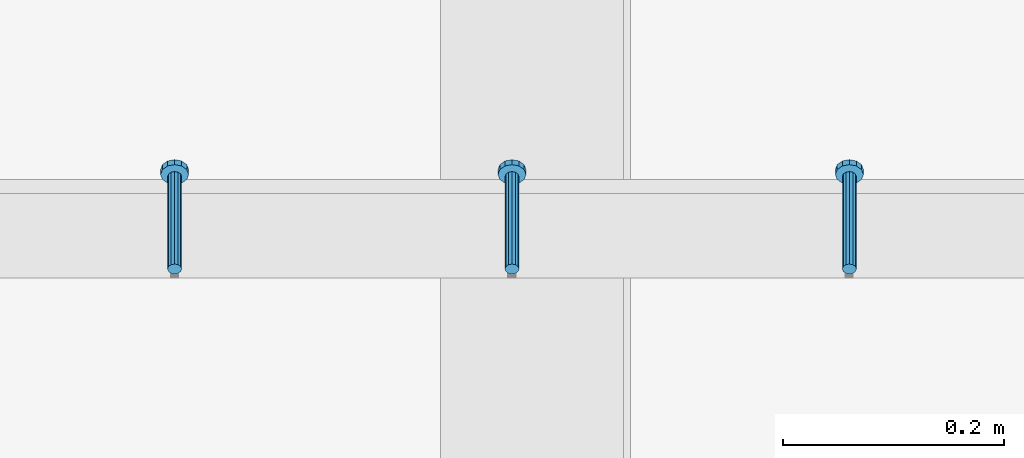
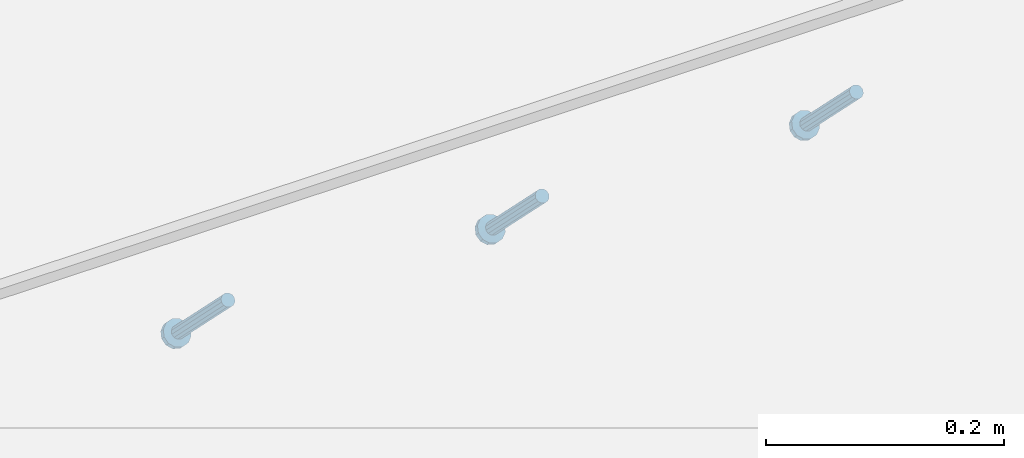
# One storey, part 2343 of 3843: 3 members, 1 element without a shape of its own.
"""IFC2X3 building model written with IfcOpenShell, lengths in millimetres."""

from ifc_helpers import new_model, si_unit, frame, origin_with_axes, place, context, subcontext, project, spatial, faceted_brep, material, type_object, element, aggregate, save


model = new_model("IFC2X3")

# Units and contexts
model_context = context("Model", 3, precision=1e-05, world=origin_with_axes())
body_context = subcontext(model_context, "Body", "Model", "MODEL_VIEW")
ifc_project = project(units=[si_unit("LENGTHUNIT", "METRE", prefix="MILLI"), si_unit("AREAUNIT", "SQUARE_METRE"), si_unit("VOLUMEUNIT", "CUBIC_METRE"), si_unit("MASSUNIT", "GRAM", prefix="KILO"), si_unit("TIMEUNIT", "SECOND"), si_unit("PLANEANGLEUNIT", "RADIAN"), si_unit("SOLIDANGLEUNIT", "STERADIAN"), si_unit("THERMODYNAMICTEMPERATUREUNIT", "DEGREE_CELSIUS"), si_unit("LUMINOUSINTENSITYUNIT", "LUMEN")], contexts=[model_context])

# Site, building, storey
site_placement = place(None, origin_with_axes())
site = spatial("IfcSite", under=ifc_project, at=site_placement, CompositionType="ELEMENT")
building_placement = place(site_placement, origin_with_axes())
building = spatial("IfcBuilding", under=site, at=building_placement, Name="Undefined", CompositionType="ELEMENT")
storey_placement = place(building_placement, origin_with_axes())
storey = spatial("IfcBuildingStorey", under=building, at=storey_placement, Name="Undefined", CompositionType="ELEMENT", Elevation=0.0)

# Assembly, members
assembly_placement = place(storey_placement, origin_with_axes())
assembly = element("IfcElementAssembly", 1, at=assembly_placement, inside=storey, Name="EMBED_ANGLE", AssemblyPlace="NOTDEFINED", PredefinedType="RIGID_FRAME")
ifc_material = material(Name="STEEL/A108")
member_type = type_object("IfcMemberType", PredefinedType="NOTDEFINED")
member_1_placement = place(assembly_placement, frame((61240.1619023437, 62012.5124999965, 30446.6625000001), z_axis=(-1.0, 0.0, 0.0), x_axis=(5.70000238222118e-08, 0.707106781186546, -0.707106781186546)))
member_1 = element("IfcMember", 2, at=member_1_placement, type_object=member_type, material=ifc_material, Name="HEADED STUD ANCHOR", context=body_context, shape_type="Brep", body=[
    faceted_brep([(7.27595761418343e-12, -3.18000006675175, 5.5), (0.0, -5.49999999998363, 3.1800000667572), (118.110000000976, -5.49999999999091, 3.1800000667572), (118.110000000983, -3.18000006675175, 5.5), (0.0, -6.3499999046162, 0.0), (118.110000000968, -6.34999990461256, 0.0), (0.0, -5.49999999998363, -3.1800000667572), (118.110000000976, -5.49999999999091, -3.1800000667572), (7.27595761418343e-12, -3.18000006675175, -5.5), (118.110000000983, -3.18000006675175, -5.5), (7.27595761418343e-12, -1.81898940354586e-12, -6.34999990463257), (118.110000000968, -1.81898940354586e-12, -6.34999990463257), (0.0, 3.18000006675175, -5.5), (118.110000000968, 3.18000006674811, -5.5), (7.27595761418343e-12, 5.49999999998363, -3.1800000667572), (118.110000000983, 5.49999999998363, -3.1800000667572), (7.27595761418343e-12, 6.3499999046162, 0.0), (118.110000000976, 6.34999990461256, 0.0), (7.27595761418343e-12, 5.49999999998363, 3.1800000667572), (118.110000000983, 5.49999999998363, 3.1800000667572), (0.0, 3.18000006675175, 5.5), (118.110000000968, 3.18000006674811, 5.5), (7.27595761418343e-12, -1.81898940354586e-12, 6.34999990463257), (118.110000000968, -1.81898940354586e-12, 6.34999990463257), (120.650000000991, -10.9899997710909, 6.34999990463257), (120.650000000998, -6.34000015257152, 10.9899997711182), (120.650000000991, -12.6999998092379, 0.0), (120.650000000991, -10.9899997710909, -6.34999990463257), (120.650000000998, -6.34000015257152, -10.9899997711182), (120.650000000991, -1.81898940354586e-12, -12.6899995803833), (120.650000000991, 6.34000015257152, -10.9899997711182), (120.650000000998, 10.9899997710909, -6.34999990463257), (120.650000000991, 12.6999998092342, 0.0), (120.650000000998, 10.9899997710909, 6.34999990463257), (120.650000000991, 6.34000015257152, 10.9899997711182), (120.650000000991, -1.81898940354586e-12, 12.6899995803833), (127.000000001048, -10.9899997710945, 6.34999990463257), (127.000000001048, -6.34000015257152, 10.9899997711182), (127.000000001048, -12.6999998092342, 0.0), (127.000000001048, -10.9899997710945, -6.34999990463257), (127.000000001048, -6.34000015257152, -10.9899997711182), (127.000000001048, 1.81898940354586e-12, -12.6899995803833), (127.000000001048, 6.34000015256788, -10.9899997711182), (127.000000001048, 10.9899997710909, -6.34999990463257), (127.000000001048, 12.6999998092379, 0.0), (127.000000001048, 10.9899997710909, 6.34999990463257), (127.000000001048, 6.34000015256788, 10.9899997711182), (127.000000001048, 1.81898940354586e-12, 12.6899995803833)], [[[0, 1, 2, 3]], [[1, 4, 5, 2]], [[4, 6, 7, 5]], [[6, 8, 9, 7]], [[8, 10, 11, 9]], [[10, 12, 13, 11]], [[12, 14, 15, 13]], [[14, 16, 17, 15]], [[16, 18, 19, 17]], [[18, 20, 21, 19]], [[20, 22, 23, 21]], [[22, 0, 3, 23]], [[22, 20, 18, 16, 14, 12, 10, 8, 6, 4, 1, 0]], [[3, 2, 24, 25]], [[2, 5, 26, 24]], [[5, 7, 27, 26]], [[7, 9, 28, 27]], [[9, 11, 29, 28]], [[11, 13, 30, 29]], [[13, 15, 31, 30]], [[15, 17, 32, 31]], [[17, 19, 33, 32]], [[19, 21, 34, 33]], [[21, 23, 35, 34]], [[23, 3, 25, 35]], [[25, 24, 36, 37]], [[24, 26, 38, 36]], [[26, 27, 39, 38]], [[27, 28, 40, 39]], [[28, 29, 41, 40]], [[29, 30, 42, 41]], [[30, 31, 43, 42]], [[31, 32, 44, 43]], [[32, 33, 45, 44]], [[33, 34, 46, 45]], [[34, 35, 47, 46]], [[35, 25, 37, 47]], [[38, 39, 40, 41, 42, 43, 44, 45, 46, 47, 37, 36]]]),
])
member_2_placement = place(assembly_placement, frame((60935.3619023437, 62012.5124999965, 30446.6625000001), z_axis=(-1.0, 0.0, 0.0), x_axis=(5.70000238222118e-08, 0.707106781186546, -0.707106781186546)))
member_2 = element("IfcMember", 3, at=member_2_placement, type_object=member_type, material=ifc_material, Name="HEADED STUD ANCHOR", context=body_context, shape_type="Brep", body=[
    faceted_brep([(7.27595761418343e-12, -3.18000006675175, 5.5), (0.0, -5.49999999998363, 3.1800000667572), (118.110000000976, -5.49999999999091, 3.1800000667572), (118.110000000983, -3.18000006675175, 5.5), (0.0, -6.3499999046162, 0.0), (118.110000000968, -6.34999990461256, 0.0), (0.0, -5.49999999998363, -3.1800000667572), (118.110000000976, -5.49999999999091, -3.1800000667572), (7.27595761418343e-12, -3.18000006675175, -5.5), (118.110000000983, -3.18000006675175, -5.5), (7.27595761418343e-12, -1.81898940354586e-12, -6.34999990463257), (118.110000000968, -1.81898940354586e-12, -6.34999990463257), (0.0, 3.18000006675175, -5.5), (118.110000000968, 3.18000006674811, -5.5), (7.27595761418343e-12, 5.49999999998363, -3.1800000667572), (118.110000000983, 5.49999999998363, -3.1800000667572), (7.27595761418343e-12, 6.3499999046162, 0.0), (118.110000000976, 6.34999990461256, 0.0), (7.27595761418343e-12, 5.49999999998363, 3.1800000667572), (118.110000000983, 5.49999999998363, 3.1800000667572), (0.0, 3.18000006675175, 5.5), (118.110000000968, 3.18000006674811, 5.5), (7.27595761418343e-12, -1.81898940354586e-12, 6.34999990463257), (118.110000000968, -1.81898940354586e-12, 6.34999990463257), (120.650000000991, -10.9899997710909, 6.34999990463257), (120.650000000998, -6.34000015257152, 10.9899997711182), (120.650000000991, -12.6999998092379, 0.0), (120.650000000991, -10.9899997710909, -6.34999990463257), (120.650000000998, -6.34000015257152, -10.9899997711182), (120.650000000991, -1.81898940354586e-12, -12.6899995803833), (120.650000000991, 6.34000015257152, -10.9899997711182), (120.650000000998, 10.9899997710909, -6.34999990463257), (120.650000000991, 12.6999998092342, 0.0), (120.650000000998, 10.9899997710909, 6.34999990463257), (120.650000000991, 6.34000015257152, 10.9899997711182), (120.650000000991, -1.81898940354586e-12, 12.6899995803833), (127.000000001048, -10.9899997710945, 6.34999990463257), (127.000000001048, -6.34000015257152, 10.9899997711182), (127.000000001048, -12.6999998092342, 0.0), (127.000000001048, -10.9899997710945, -6.34999990463257), (127.000000001048, -6.34000015257152, -10.9899997711182), (127.000000001048, 1.81898940354586e-12, -12.6899995803833), (127.000000001048, 6.34000015256788, -10.9899997711182), (127.000000001048, 10.9899997710909, -6.34999990463257), (127.000000001048, 12.6999998092379, 0.0), (127.000000001048, 10.9899997710909, 6.34999990463257), (127.000000001048, 6.34000015256788, 10.9899997711182), (127.000000001048, 1.81898940354586e-12, 12.6899995803833)], [[[0, 1, 2, 3]], [[1, 4, 5, 2]], [[4, 6, 7, 5]], [[6, 8, 9, 7]], [[8, 10, 11, 9]], [[10, 12, 13, 11]], [[12, 14, 15, 13]], [[14, 16, 17, 15]], [[16, 18, 19, 17]], [[18, 20, 21, 19]], [[20, 22, 23, 21]], [[22, 0, 3, 23]], [[22, 20, 18, 16, 14, 12, 10, 8, 6, 4, 1, 0]], [[3, 2, 24, 25]], [[2, 5, 26, 24]], [[5, 7, 27, 26]], [[7, 9, 28, 27]], [[9, 11, 29, 28]], [[11, 13, 30, 29]], [[13, 15, 31, 30]], [[15, 17, 32, 31]], [[17, 19, 33, 32]], [[19, 21, 34, 33]], [[21, 23, 35, 34]], [[23, 3, 25, 35]], [[25, 24, 36, 37]], [[24, 26, 38, 36]], [[26, 27, 39, 38]], [[27, 28, 40, 39]], [[28, 29, 41, 40]], [[29, 30, 42, 41]], [[30, 31, 43, 42]], [[31, 32, 44, 43]], [[32, 33, 45, 44]], [[33, 34, 46, 45]], [[34, 35, 47, 46]], [[35, 25, 37, 47]], [[38, 39, 40, 41, 42, 43, 44, 45, 46, 47, 37, 36]]]),
])
member_3_placement = place(assembly_placement, frame((60630.5619023437, 62012.5124999965, 30446.6625000001), z_axis=(-1.0, 0.0, 0.0), x_axis=(5.70000238222118e-08, 0.707106781186546, -0.707106781186546)))
member_3 = element("IfcMember", 4, at=member_3_placement, type_object=member_type, material=ifc_material, Name="HEADED STUD ANCHOR", context=body_context, shape_type="Brep", body=[
    faceted_brep([(7.27595761418343e-12, -3.18000006675175, 5.5), (0.0, -5.49999999998363, 3.1800000667572), (118.110000000976, -5.49999999999091, 3.1800000667572), (118.110000000983, -3.18000006675175, 5.5), (0.0, -6.3499999046162, 0.0), (118.110000000968, -6.34999990461256, 0.0), (0.0, -5.49999999998363, -3.1800000667572), (118.110000000976, -5.49999999999091, -3.1800000667572), (7.27595761418343e-12, -3.18000006675175, -5.5), (118.110000000983, -3.18000006675175, -5.5), (7.27595761418343e-12, -1.81898940354586e-12, -6.34999990463257), (118.110000000968, -1.81898940354586e-12, -6.34999990463257), (0.0, 3.18000006675175, -5.5), (118.110000000968, 3.18000006674811, -5.5), (7.27595761418343e-12, 5.49999999998363, -3.1800000667572), (118.110000000983, 5.49999999998363, -3.1800000667572), (7.27595761418343e-12, 6.3499999046162, 0.0), (118.110000000976, 6.34999990461256, 0.0), (7.27595761418343e-12, 5.49999999998363, 3.1800000667572), (118.110000000983, 5.49999999998363, 3.1800000667572), (0.0, 3.18000006675175, 5.5), (118.110000000968, 3.18000006674811, 5.5), (7.27595761418343e-12, -1.81898940354586e-12, 6.34999990463257), (118.110000000968, -1.81898940354586e-12, 6.34999990463257), (120.650000000991, -10.9899997710909, 6.34999990463257), (120.650000000998, -6.34000015257152, 10.9899997711182), (120.650000000991, -12.6999998092379, 0.0), (120.650000000991, -10.9899997710909, -6.34999990463257), (120.650000000998, -6.34000015257152, -10.9899997711182), (120.650000000991, -1.81898940354586e-12, -12.6899995803833), (120.650000000991, 6.34000015257152, -10.9899997711182), (120.650000000998, 10.9899997710909, -6.34999990463257), (120.650000000991, 12.6999998092342, 0.0), (120.650000000998, 10.9899997710909, 6.34999990463257), (120.650000000991, 6.34000015257152, 10.9899997711182), (120.650000000991, -1.81898940354586e-12, 12.6899995803833), (127.000000001048, -10.9899997710945, 6.34999990463257), (127.000000001048, -6.34000015257152, 10.9899997711182), (127.000000001048, -12.6999998092342, 0.0), (127.000000001048, -10.9899997710945, -6.34999990463257), (127.000000001048, -6.34000015257152, -10.9899997711182), (127.000000001048, 1.81898940354586e-12, -12.6899995803833), (127.000000001048, 6.34000015256788, -10.9899997711182), (127.000000001048, 10.9899997710909, -6.34999990463257), (127.000000001048, 12.6999998092379, 0.0), (127.000000001048, 10.9899997710909, 6.34999990463257), (127.000000001048, 6.34000015256788, 10.9899997711182), (127.000000001048, 1.81898940354586e-12, 12.6899995803833)], [[[0, 1, 2, 3]], [[1, 4, 5, 2]], [[4, 6, 7, 5]], [[6, 8, 9, 7]], [[8, 10, 11, 9]], [[10, 12, 13, 11]], [[12, 14, 15, 13]], [[14, 16, 17, 15]], [[16, 18, 19, 17]], [[18, 20, 21, 19]], [[20, 22, 23, 21]], [[22, 0, 3, 23]], [[22, 20, 18, 16, 14, 12, 10, 8, 6, 4, 1, 0]], [[3, 2, 24, 25]], [[2, 5, 26, 24]], [[5, 7, 27, 26]], [[7, 9, 28, 27]], [[9, 11, 29, 28]], [[11, 13, 30, 29]], [[13, 15, 31, 30]], [[15, 17, 32, 31]], [[17, 19, 33, 32]], [[19, 21, 34, 33]], [[21, 23, 35, 34]], [[23, 3, 25, 35]], [[25, 24, 36, 37]], [[24, 26, 38, 36]], [[26, 27, 39, 38]], [[27, 28, 40, 39]], [[28, 29, 41, 40]], [[29, 30, 42, 41]], [[30, 31, 43, 42]], [[31, 32, 44, 43]], [[32, 33, 45, 44]], [[33, 34, 46, 45]], [[34, 35, 47, 46]], [[35, 25, 37, 47]], [[38, 39, 40, 41, 42, 43, 44, 45, 46, 47, 37, 36]]]),
])
aggregate(assembly, [member_1, member_2, member_3])

save(model, "model.ifc")
